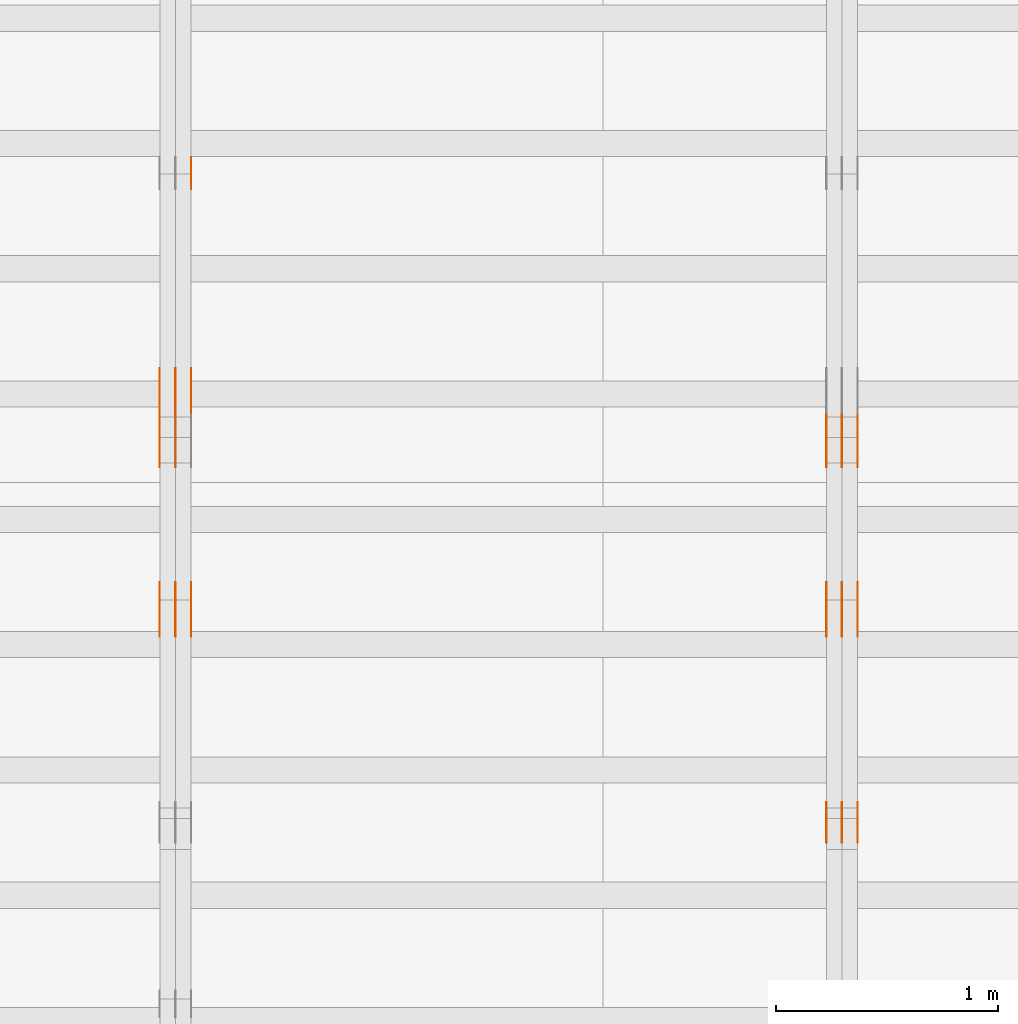
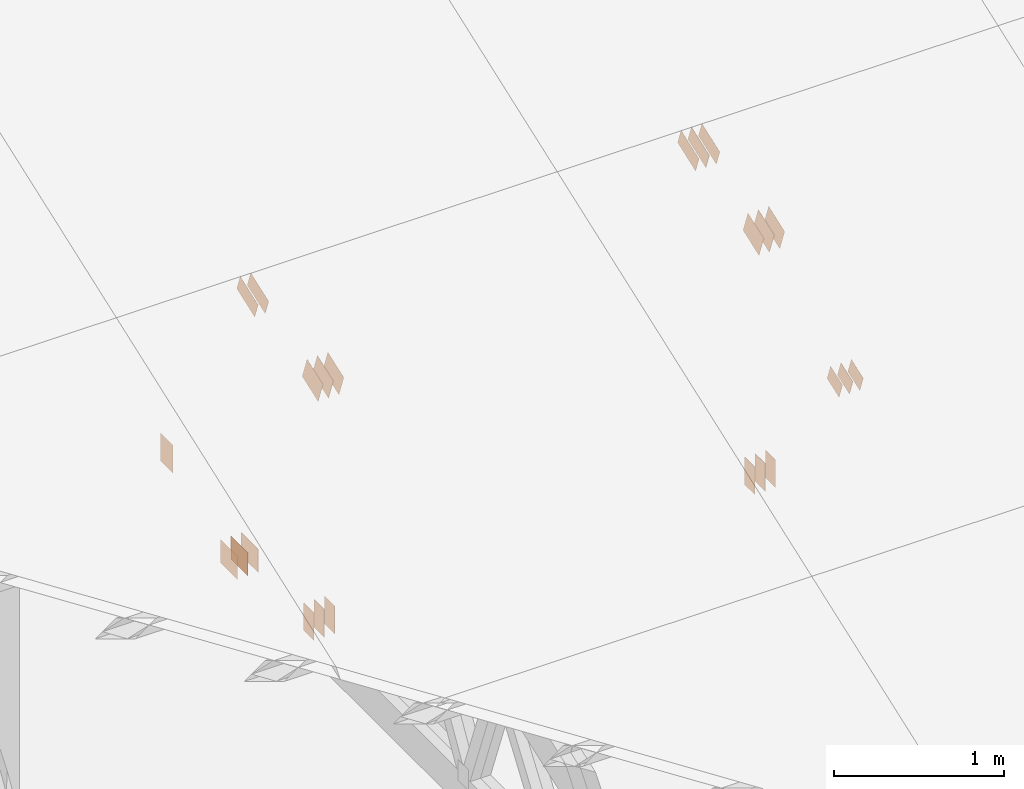
# One storey, part 87 of 189: 31 proxies.
"""IFC2X3 building model written with IfcOpenShell, lengths in millimetres."""

from ifc_helpers import new_model, entity, si_unit, converted_unit, derived_unit, direction, frame, frame_2d, origin, origin_2d_with_axis, place, context, subcontext, project, spatial, polyline, rectangle, outline, extrude, source, transform, mapped, material, type_object, type_shapes, element, save


model = new_model("IFC2X3")

# Units and contexts
model_context = context("Model", 3, precision=0.01, world=origin(), true_north=direction((6.12303176911189e-17, 1.0)))
body_context = subcontext(model_context, "Body", "Model", "MODEL_VIEW")
ifc_project = project(units=[si_unit("LENGTHUNIT", "METRE", prefix="MILLI"), si_unit("AREAUNIT", "SQUARE_METRE"), si_unit("VOLUMEUNIT", "CUBIC_METRE"), converted_unit("PLANEANGLEUNIT", "DEGREE", entity("IfcRatioMeasure", 0.0174532925199433), si_unit("PLANEANGLEUNIT", "RADIAN"), dimensions=[0, 0, 0, 0, 0, 0, 0]), si_unit("MASSUNIT", "GRAM", prefix="KILO"), derived_unit("MASSDENSITYUNIT", [(si_unit("MASSUNIT", "GRAM", prefix="KILO"), 1), (si_unit("LENGTHUNIT", "METRE"), -3)]), si_unit("TIMEUNIT", "SECOND"), si_unit("FREQUENCYUNIT", "HERTZ"), si_unit("THERMODYNAMICTEMPERATUREUNIT", "DEGREE_CELSIUS"), derived_unit("THERMALTRANSMITTANCEUNIT", [(si_unit("MASSUNIT", "GRAM", prefix="KILO"), 1), (si_unit("THERMODYNAMICTEMPERATUREUNIT", "KELVIN"), -1), (si_unit("TIMEUNIT", "SECOND"), -3)]), derived_unit("VOLUMETRICFLOWRATEUNIT", [(si_unit("LENGTHUNIT", "METRE"), 3), (si_unit("TIMEUNIT", "SECOND"), -1)]), si_unit("ELECTRICCURRENTUNIT", "AMPERE"), si_unit("ELECTRICVOLTAGEUNIT", "VOLT"), si_unit("POWERUNIT", "WATT"), si_unit("FORCEUNIT", "NEWTON"), si_unit("ILLUMINANCEUNIT", "LUX"), si_unit("LUMINOUSFLUXUNIT", "LUMEN"), si_unit("LUMINOUSINTENSITYUNIT", "CANDELA"), derived_unit("USERDEFINED", [(si_unit("MASSUNIT", "GRAM", prefix="KILO"), -1), (si_unit("LENGTHUNIT", "METRE"), -2), (si_unit("TIMEUNIT", "SECOND"), 3), (si_unit("LUMINOUSFLUXUNIT", "LUMEN"), 1)]), derived_unit("LINEARVELOCITYUNIT", [(si_unit("LENGTHUNIT", "METRE"), 1), (si_unit("TIMEUNIT", "SECOND"), -1)]), si_unit("PRESSUREUNIT", "PASCAL"), derived_unit("USERDEFINED", [(si_unit("LENGTHUNIT", "METRE"), -2), (si_unit("MASSUNIT", "GRAM", prefix="KILO"), 1), (si_unit("TIMEUNIT", "SECOND"), -2)])], contexts=[model_context])

# Site, building, storey
site_placement = place(None, origin())
site = spatial("IfcSite", under=ifc_project, at=site_placement, CompositionType="ELEMENT")
building_placement = place(site_placement, origin())
building = spatial("IfcBuilding", under=site, at=building_placement, CompositionType="ELEMENT")
storey_placement = place(building_placement, origin())
storey = spatial("IfcBuildingStorey", under=building, at=storey_placement, Name="Default", CompositionType="ELEMENT", Elevation=0.0)

# Proxies
ifc_material_1 = material(Name="IfcSurfaceStyle #106706")
building_element_proxy_type_1 = type_object("IfcBuildingElementProxyType", PredefinedType="NOTDEFINED", material=ifc_material_1)
shared_shape_1 = source(origin(), body_context, "Body", "SweptSolid", [
    extrude(outline(polyline([(-112.500654374667, -59.9999021691247), (112.500117969231, -59.9999021691247), (112.500612624162, 59.9999021691247), (-112.500076218726, 59.9999021691247), (-112.500654374667, -59.9999021691247)])), frame((112.500612624162, 60.0003514046321, 0.0), z_axis=(0.0, 0.0, 1.0), x_axis=(-1.0, 0.0, 0.0)), (0.0, 0.0, 1.0), 1.3),
])
type_shapes(building_element_proxy_type_1, [shared_shape_1])
proxy_1_placement = place(building_placement, frame((18301.3, 5418.0703125, 2162.37353515625), z_axis=(-1.0, 0.0, 0.0), x_axis=(0.0, 0.939692620785908, 0.342020143325669)))
element("IfcBuildingElementProxy", 1, at=proxy_1_placement, inside=storey, type_object=building_element_proxy_type_1, material=ifc_material_1, context=body_context, shape_type="MappedRepresentation", body=[
    mapped(shared_shape_1, transform((0.0, 0.0, 0.0), scale=1.0)),
])
ifc_material_2 = material(Name="IfcSurfaceStyle #106649")
building_element_proxy_type_2 = type_object("IfcBuildingElementProxyType", PredefinedType="NOTDEFINED", material=ifc_material_2)
shared_shape_2 = source(origin(), body_context, "Body", "SweptSolid", [
    extrude(outline(polyline([(-112.500654374667, -59.9999021691247), (112.500117969231, -59.9999021691247), (112.500612624162, 59.9999021691247), (-112.500076218726, 59.9999021691247), (-112.500654374667, -59.9999021691247)])), frame((112.500612624162, 60.0003514046321, 0.0), z_axis=(0.0, 0.0, 1.0), x_axis=(-1.0, 0.0, 0.0)), (0.0, 0.0, 1.0), 1.29999999999998),
])
type_shapes(building_element_proxy_type_2, [shared_shape_2])
proxy_2_placement = place(building_placement, frame((18230.0, 5418.0703125, 2162.37353515625), z_axis=(-1.0, 0.0, 0.0), x_axis=(0.0, 0.939692620785908, 0.342020143325669)))
element("IfcBuildingElementProxy", 2, at=proxy_2_placement, inside=storey, type_object=building_element_proxy_type_2, material=ifc_material_2, context=body_context, shape_type="MappedRepresentation", body=[
    mapped(shared_shape_2, transform((0.0, 0.0, 0.0), scale=1.0)),
])
ifc_material_3 = material(Name="IfcSurfaceStyle #106592")
building_element_proxy_type_3 = type_object("IfcBuildingElementProxyType", PredefinedType="NOTDEFINED", material=ifc_material_3)
shared_shape_3 = source(origin(), body_context, "Body", "SweptSolid", [
    extrude(outline(polyline([(-112.500654374667, -59.9999021691247), (112.500117969231, -59.9999021691247), (112.500612624162, 59.9999021691247), (-112.500076218726, 59.9999021691247), (-112.500654374667, -59.9999021691247)])), frame((112.500612624162, 60.0003514046321, 0.0), z_axis=(0.0, 0.0, 1.0), x_axis=(-1.0, 0.0, 0.0)), (0.0, 0.0, 1.0), 1.29999999999998),
])
type_shapes(building_element_proxy_type_3, [shared_shape_3])
proxy_3_placement = place(building_placement, frame((18231.3, 5418.0703125, 2162.37353515625), z_axis=(-1.0, 0.0, 0.0), x_axis=(0.0, 0.939692620785908, 0.342020143325669)))
element("IfcBuildingElementProxy", 3, at=proxy_3_placement, inside=storey, type_object=building_element_proxy_type_3, material=ifc_material_3, context=body_context, shape_type="MappedRepresentation", body=[
    mapped(shared_shape_3, transform((0.0, 0.0, 0.0), scale=1.0)),
])
ifc_material_4 = material(Name="IfcSurfaceStyle #106535")
building_element_proxy_type_4 = type_object("IfcBuildingElementProxyType", PredefinedType="NOTDEFINED", material=ifc_material_4)
shared_shape_4 = source(origin(), body_context, "Body", "SweptSolid", [
    extrude(outline(polyline([(-112.500654374667, -59.9999021691247), (112.500117969231, -59.9999021691247), (112.500612624162, 59.9999021691247), (-112.500076218726, 59.9999021691247), (-112.500654374667, -59.9999021691247)])), frame((112.500612624162, 60.0003514046321, 0.0), z_axis=(0.0, 0.0, 1.0), x_axis=(-1.0, 0.0, 0.0)), (0.0, 0.0, 1.0), 1.29999999999999),
])
type_shapes(building_element_proxy_type_4, [shared_shape_4])
proxy_4_placement = place(building_placement, frame((18160.0, 5418.0703125, 2162.37353515625), z_axis=(-1.0, 0.0, 0.0), x_axis=(0.0, 0.939692620785908, 0.342020143325669)))
element("IfcBuildingElementProxy", 4, at=proxy_4_placement, inside=storey, type_object=building_element_proxy_type_4, material=ifc_material_4, context=body_context, shape_type="MappedRepresentation", body=[
    mapped(shared_shape_4, transform((0.0, 0.0, 0.0), scale=1.0)),
])
ifc_material_5 = material(Name="IfcSurfaceStyle #106022")
building_element_proxy_type_5 = type_object("IfcBuildingElementProxyType", PredefinedType="NOTDEFINED", material=ifc_material_5)
shared_shape_5 = source(origin(), body_context, "Body", "SweptSolid", [
    extrude(rectangle(XDim=200.0, YDim=120.0, at=origin_2d_with_axis()), frame((100.0, 60.0, 0.0), z_axis=(0.0, 0.0, 1.0), x_axis=(-1.0, 0.0, 0.0)), (0.0, 0.0, 1.0), 1.3),
])
type_shapes(building_element_proxy_type_5, [shared_shape_5])
proxy_5_placement = place(building_placement, frame((18301.3, 4760.65625, 145.0), z_axis=(-1.0, 0.0, 0.0), x_axis=(0.0, 0.0, 1.0)))
element("IfcBuildingElementProxy", 5, at=proxy_5_placement, inside=storey, type_object=building_element_proxy_type_5, material=ifc_material_5, context=body_context, shape_type="MappedRepresentation", body=[
    mapped(shared_shape_5, transform((0.0, 0.0, 0.0), scale=1.0)),
])
ifc_material_6 = material(Name="IfcSurfaceStyle #105965")
building_element_proxy_type_6 = type_object("IfcBuildingElementProxyType", PredefinedType="NOTDEFINED", material=ifc_material_6)
shared_shape_6 = source(origin(), body_context, "Body", "SweptSolid", [
    extrude(rectangle(XDim=200.0, YDim=120.0, at=origin_2d_with_axis()), frame((100.0, 60.0, 0.0), z_axis=(0.0, 0.0, 1.0), x_axis=(-1.0, 0.0, 0.0)), (0.0, 0.0, 1.0), 1.29999999999998),
])
type_shapes(building_element_proxy_type_6, [shared_shape_6])
proxy_6_placement = place(building_placement, frame((18230.0, 4760.65625, 145.0), z_axis=(-1.0, 0.0, 0.0), x_axis=(0.0, 0.0, 1.0)))
element("IfcBuildingElementProxy", 6, at=proxy_6_placement, inside=storey, type_object=building_element_proxy_type_6, material=ifc_material_6, context=body_context, shape_type="MappedRepresentation", body=[
    mapped(shared_shape_6, transform((0.0, 0.0, 0.0), scale=1.0)),
])
ifc_material_7 = material(Name="IfcSurfaceStyle #105908")
building_element_proxy_type_7 = type_object("IfcBuildingElementProxyType", PredefinedType="NOTDEFINED", material=ifc_material_7)
shared_shape_7 = source(origin(), body_context, "Body", "SweptSolid", [
    extrude(rectangle(XDim=200.0, YDim=120.0, at=origin_2d_with_axis()), frame((100.0, 60.0, 0.0), z_axis=(0.0, 0.0, 1.0), x_axis=(-1.0, 0.0, 0.0)), (0.0, 0.0, 1.0), 1.29999999999998),
])
type_shapes(building_element_proxy_type_7, [shared_shape_7])
proxy_7_placement = place(building_placement, frame((18231.3, 4760.65625, 145.0), z_axis=(-1.0, 0.0, 0.0), x_axis=(0.0, 0.0, 1.0)))
element("IfcBuildingElementProxy", 7, at=proxy_7_placement, inside=storey, type_object=building_element_proxy_type_7, material=ifc_material_7, context=body_context, shape_type="MappedRepresentation", body=[
    mapped(shared_shape_7, transform((0.0, 0.0, 0.0), scale=1.0)),
])
ifc_material_8 = material(Name="IfcSurfaceStyle #105851")
building_element_proxy_type_8 = type_object("IfcBuildingElementProxyType", PredefinedType="NOTDEFINED", material=ifc_material_8)
shared_shape_8 = source(origin(), body_context, "Body", "SweptSolid", [
    extrude(rectangle(XDim=200.0, YDim=120.0, at=origin_2d_with_axis()), frame((100.0, 60.0, 0.0), z_axis=(0.0, 0.0, 1.0), x_axis=(-1.0, 0.0, 0.0)), (0.0, 0.0, 1.0), 1.29999999999999),
])
type_shapes(building_element_proxy_type_8, [shared_shape_8])
proxy_8_placement = place(building_placement, frame((18160.0, 4760.65625, 145.0), z_axis=(-1.0, 0.0, 0.0), x_axis=(0.0, 0.0, 1.0)))
element("IfcBuildingElementProxy", 8, at=proxy_8_placement, inside=storey, type_object=building_element_proxy_type_8, material=ifc_material_8, context=body_context, shape_type="MappedRepresentation", body=[
    mapped(shared_shape_8, transform((0.0, 0.0, 0.0), scale=1.0)),
])
ifc_material_9 = material(Name="IfcSurfaceStyle #105794")
building_element_proxy_type_9 = type_object("IfcBuildingElementProxyType", PredefinedType="NOTDEFINED", material=ifc_material_9)
shared_shape_9 = source(origin(), body_context, "Body", "SweptSolid", [
    extrude(outline(polyline([(-74.9994515581384, -59.9999039432178), (74.9998536965286, -59.9999039432178), (75.0003483514593, 59.9999039432178), (-75.0007504898495, 59.9999039432178), (-74.9994515581384, -59.9999039432178)])), frame((75.0003483514593, 60.0003496305408, 0.0), z_axis=(0.0, 0.0, 1.0), x_axis=(-1.0, 0.0, 0.0)), (0.0, 0.0, 1.0), 1.3),
])
type_shapes(building_element_proxy_type_9, [shared_shape_9])
proxy_9_placement = place(building_placement, frame((18301.3, 3726.8984375, 1559.607421875), z_axis=(-1.0, 0.0, 0.0), x_axis=(0.0, 0.939692620785908, 0.342020143325669)))
element("IfcBuildingElementProxy", 9, at=proxy_9_placement, inside=storey, type_object=building_element_proxy_type_9, material=ifc_material_9, context=body_context, shape_type="MappedRepresentation", body=[
    mapped(shared_shape_9, transform((0.0, 0.0, 0.0), scale=1.0)),
])
ifc_material_10 = material(Name="IfcSurfaceStyle #105737")
building_element_proxy_type_10 = type_object("IfcBuildingElementProxyType", PredefinedType="NOTDEFINED", material=ifc_material_10)
shared_shape_10 = source(origin(), body_context, "Body", "SweptSolid", [
    extrude(outline(polyline([(-74.9994515581384, -59.9999039432178), (74.9998536965286, -59.9999039432178), (75.0003483514593, 59.9999039432178), (-75.0007504898495, 59.9999039432178), (-74.9994515581384, -59.9999039432178)])), frame((75.0003483514593, 60.0003496305408, 0.0), z_axis=(0.0, 0.0, 1.0), x_axis=(-1.0, 0.0, 0.0)), (0.0, 0.0, 1.0), 1.29999999999999),
])
type_shapes(building_element_proxy_type_10, [shared_shape_10])
proxy_10_placement = place(building_placement, frame((18230.0, 3726.8984375, 1559.607421875), z_axis=(-1.0, 0.0, 0.0), x_axis=(0.0, 0.939692620785908, 0.342020143325669)))
element("IfcBuildingElementProxy", 10, at=proxy_10_placement, inside=storey, type_object=building_element_proxy_type_10, material=ifc_material_10, context=body_context, shape_type="MappedRepresentation", body=[
    mapped(shared_shape_10, transform((0.0, 0.0, 0.0), scale=1.0)),
])
ifc_material_11 = material(Name="IfcSurfaceStyle #105680")
building_element_proxy_type_11 = type_object("IfcBuildingElementProxyType", PredefinedType="NOTDEFINED", material=ifc_material_11)
shared_shape_11 = source(origin(), body_context, "Body", "SweptSolid", [
    extrude(outline(polyline([(-74.9994515581384, -59.9999039432178), (74.9998536965286, -59.9999039432178), (75.0003483514593, 59.9999039432178), (-75.0007504898495, 59.9999039432178), (-74.9994515581384, -59.9999039432178)])), frame((75.0003483514593, 60.0003496305408, 0.0), z_axis=(0.0, 0.0, 1.0), x_axis=(-1.0, 0.0, 0.0)), (0.0, 0.0, 1.0), 1.29999999999999),
])
type_shapes(building_element_proxy_type_11, [shared_shape_11])
proxy_11_placement = place(building_placement, frame((18231.3, 3726.8984375, 1559.607421875), z_axis=(-1.0, 0.0, 0.0), x_axis=(0.0, 0.939692620785908, 0.342020143325669)))
element("IfcBuildingElementProxy", 11, at=proxy_11_placement, inside=storey, type_object=building_element_proxy_type_11, material=ifc_material_11, context=body_context, shape_type="MappedRepresentation", body=[
    mapped(shared_shape_11, transform((0.0, 0.0, 0.0), scale=1.0)),
])
ifc_material_12 = material(Name="IfcSurfaceStyle #105623")
building_element_proxy_type_12 = type_object("IfcBuildingElementProxyType", PredefinedType="NOTDEFINED", material=ifc_material_12)
shared_shape_12 = source(origin(), body_context, "Body", "SweptSolid", [
    extrude(outline(polyline([(-74.9994515581384, -59.9999039432178), (74.9998536965286, -59.9999039432178), (75.0003483514593, 59.9999039432178), (-75.0007504898495, 59.9999039432178), (-74.9994515581384, -59.9999039432178)])), frame((75.0003483514593, 60.0003496305408, 0.0), z_axis=(0.0, 0.0, 1.0), x_axis=(-1.0, 0.0, 0.0)), (0.0, 0.0, 1.0), 1.29999999999999),
])
type_shapes(building_element_proxy_type_12, [shared_shape_12])
proxy_12_placement = place(building_placement, frame((18160.0, 3726.8984375, 1559.607421875), z_axis=(-1.0, 0.0, 0.0), x_axis=(0.0, 0.939692620785908, 0.342020143325669)))
element("IfcBuildingElementProxy", 12, at=proxy_12_placement, inside=storey, type_object=building_element_proxy_type_12, material=ifc_material_12, context=body_context, shape_type="MappedRepresentation", body=[
    mapped(shared_shape_12, transform((0.0, 0.0, 0.0), scale=1.0)),
])
ifc_material_13 = material(Name="IfcSurfaceStyle #101126")
building_element_proxy_type_13 = type_object("IfcBuildingElementProxyType", PredefinedType="NOTDEFINED", material=ifc_material_13)
shared_shape_13 = source(origin(), body_context, "Body", "SweptSolid", [
    extrude(outline(polyline([(-99.9993269270171, -84.0000832532405), (99.9997189122032, -84.0000832532405), (99.9992851765118, 84.0000832532405), (-99.999677161698, 84.0000832532405), (-99.9993269270171, -84.0000832532405)])), frame((99.9999283659736, 84.0000832532405, 0.0), z_axis=(0.0, 0.0, 1.0), x_axis=(-1.0, 0.0, 0.0)), (0.0, 0.0, 1.0), 1.3),
])
type_shapes(building_element_proxy_type_13, [shared_shape_13])
proxy_13_placement = place(building_placement, frame((18301.3, 4654.06379965055, 2052.96988554922), z_axis=(-1.0, 0.0, 0.0), x_axis=(0.0, 0.939692620785908, 0.342020143325669)))
element("IfcBuildingElementProxy", 13, at=proxy_13_placement, inside=storey, type_object=building_element_proxy_type_13, material=ifc_material_13, context=body_context, shape_type="MappedRepresentation", body=[
    mapped(shared_shape_13, transform((0.0, 0.0, 0.0), scale=1.0)),
])
ifc_material_14 = material(Name="IfcSurfaceStyle #101069")
building_element_proxy_type_14 = type_object("IfcBuildingElementProxyType", PredefinedType="NOTDEFINED", material=ifc_material_14)
shared_shape_14 = source(origin(), body_context, "Body", "SweptSolid", [
    extrude(outline(polyline([(-99.9993269270171, -84.0000832532405), (99.9997189122032, -84.0000832532405), (99.9992851765118, 84.0000832532405), (-99.999677161698, 84.0000832532405), (-99.9993269270171, -84.0000832532405)])), frame((99.9999283659736, 84.0000832532405, 0.0), z_axis=(0.0, 0.0, 1.0), x_axis=(-1.0, 0.0, 0.0)), (0.0, 0.0, 1.0), 1.29999999999998),
])
type_shapes(building_element_proxy_type_14, [shared_shape_14])
proxy_14_placement = place(building_placement, frame((18230.0, 4654.06379965055, 2052.96988554922), z_axis=(-1.0, 0.0, 0.0), x_axis=(0.0, 0.939692620785908, 0.342020143325669)))
element("IfcBuildingElementProxy", 14, at=proxy_14_placement, inside=storey, type_object=building_element_proxy_type_14, material=ifc_material_14, context=body_context, shape_type="MappedRepresentation", body=[
    mapped(shared_shape_14, transform((0.0, 0.0, 0.0), scale=1.0)),
])
ifc_material_15 = material(Name="IfcSurfaceStyle #101012")
building_element_proxy_type_15 = type_object("IfcBuildingElementProxyType", PredefinedType="NOTDEFINED", material=ifc_material_15)
shared_shape_15 = source(origin(), body_context, "Body", "SweptSolid", [
    extrude(outline(polyline([(-99.9993269270171, -84.0000832532405), (99.9997189122032, -84.0000832532405), (99.9992851765118, 84.0000832532405), (-99.999677161698, 84.0000832532405), (-99.9993269270171, -84.0000832532405)])), frame((99.9999283659736, 84.0000832532405, 0.0), z_axis=(0.0, 0.0, 1.0), x_axis=(-1.0, 0.0, 0.0)), (0.0, 0.0, 1.0), 1.29999999999998),
])
type_shapes(building_element_proxy_type_15, [shared_shape_15])
proxy_15_placement = place(building_placement, frame((18231.3, 4654.06379965055, 2052.96988554922), z_axis=(-1.0, 0.0, 0.0), x_axis=(0.0, 0.939692620785908, 0.342020143325669)))
element("IfcBuildingElementProxy", 15, at=proxy_15_placement, inside=storey, type_object=building_element_proxy_type_15, material=ifc_material_15, context=body_context, shape_type="MappedRepresentation", body=[
    mapped(shared_shape_15, transform((0.0, 0.0, 0.0), scale=1.0)),
])
ifc_material_16 = material(Name="IfcSurfaceStyle #100955")
building_element_proxy_type_16 = type_object("IfcBuildingElementProxyType", PredefinedType="NOTDEFINED", material=ifc_material_16)
shared_shape_16 = source(origin(), body_context, "Body", "SweptSolid", [
    extrude(outline(polyline([(-99.9993269270171, -84.0000832532405), (99.9997189122032, -84.0000832532405), (99.9992851765118, 84.0000832532405), (-99.999677161698, 84.0000832532405), (-99.9993269270171, -84.0000832532405)])), frame((99.9999283659736, 84.0000832532405, 0.0), z_axis=(0.0, 0.0, 1.0), x_axis=(-1.0, 0.0, 0.0)), (0.0, 0.0, 1.0), 1.29999999999999),
])
type_shapes(building_element_proxy_type_16, [shared_shape_16])
proxy_16_placement = place(building_placement, frame((18160.0, 4654.06379965055, 2052.96988554922), z_axis=(-1.0, 0.0, 0.0), x_axis=(0.0, 0.939692620785908, 0.342020143325669)))
element("IfcBuildingElementProxy", 16, at=proxy_16_placement, inside=storey, type_object=building_element_proxy_type_16, material=ifc_material_16, context=body_context, shape_type="MappedRepresentation", body=[
    mapped(shared_shape_16, transform((0.0, 0.0, 0.0), scale=1.0)),
])
ifc_material_17 = material(Name="IfcSurfaceStyle #94792")
building_element_proxy_type_17 = type_object("IfcBuildingElementProxyType", PredefinedType="NOTDEFINED", material=ifc_material_17)
shared_shape_17 = source(origin(), body_context, "Body", "SweptSolid", [
    extrude(rectangle(XDim=200.0, YDim=144.0, at=frame_2d((1.4210854715202e-14, 0.0), x_axis=(1.0, 0.0))), frame((100.0, 72.0, 0.0), z_axis=(0.0, 0.0, 1.0), x_axis=(-1.0, 0.0, 0.0)), (0.0, 0.0, 1.0), 1.3),
])
type_shapes(building_element_proxy_type_17, [shared_shape_17])
proxy_17_placement = place(building_placement, frame((15301.3, 6668.833984375, 145.0), z_axis=(-1.0, 0.0, 0.0), x_axis=(0.0, 0.0, 1.0)))
element("IfcBuildingElementProxy", 17, at=proxy_17_placement, inside=storey, type_object=building_element_proxy_type_17, material=ifc_material_17, context=body_context, shape_type="MappedRepresentation", body=[
    mapped(shared_shape_17, transform((0.0, 0.0, 0.0), scale=1.0)),
])
ifc_material_18 = material(Name="IfcSurfaceStyle #94564")
building_element_proxy_type_18 = type_object("IfcBuildingElementProxyType", PredefinedType="NOTDEFINED", material=ifc_material_18)
shared_shape_18 = source(origin(), body_context, "Body", "SweptSolid", [
    extrude(rectangle(XDim=200.0, YDim=168.0, at=origin_2d_with_axis()), frame((100.0, 84.0, 0.0), z_axis=(0.0, 0.0, 1.0), x_axis=(-1.0, 0.0, 0.0)), (0.0, 0.0, 1.0), 1.3),
])
type_shapes(building_element_proxy_type_18, [shared_shape_18])
proxy_18_placement = place(building_placement, frame((15301.3, 5662.466796875, 206.5), z_axis=(-1.0, 0.0, 0.0), x_axis=(0.0, 1.0, 0.0)))
element("IfcBuildingElementProxy", 18, at=proxy_18_placement, inside=storey, type_object=building_element_proxy_type_18, material=ifc_material_18, context=body_context, shape_type="MappedRepresentation", body=[
    mapped(shared_shape_18, transform((0.0, 0.0, 0.0), scale=1.0)),
])
ifc_material_19 = material(Name="IfcSurfaceStyle #94507")
building_element_proxy_type_19 = type_object("IfcBuildingElementProxyType", PredefinedType="NOTDEFINED", material=ifc_material_19)
shared_shape_19 = source(origin(), body_context, "Body", "SweptSolid", [
    extrude(rectangle(XDim=200.0, YDim=168.0, at=origin_2d_with_axis()), frame((100.0, 84.0, 0.0), z_axis=(0.0, 0.0, 1.0), x_axis=(-1.0, 0.0, 0.0)), (0.0, 0.0, 1.0), 1.29999999999998),
])
type_shapes(building_element_proxy_type_19, [shared_shape_19])
proxy_19_placement = place(building_placement, frame((15230.0, 5662.466796875, 206.5), z_axis=(-1.0, 0.0, 0.0), x_axis=(0.0, 1.0, 0.0)))
element("IfcBuildingElementProxy", 19, at=proxy_19_placement, inside=storey, type_object=building_element_proxy_type_19, material=ifc_material_19, context=body_context, shape_type="MappedRepresentation", body=[
    mapped(shared_shape_19, transform((0.0, 0.0, 0.0), scale=1.0)),
])
ifc_material_20 = material(Name="IfcSurfaceStyle #94450")
building_element_proxy_type_20 = type_object("IfcBuildingElementProxyType", PredefinedType="NOTDEFINED", material=ifc_material_20)
shared_shape_20 = source(origin(), body_context, "Body", "SweptSolid", [
    extrude(rectangle(XDim=200.0, YDim=168.0, at=origin_2d_with_axis()), frame((100.0, 84.0, 0.0), z_axis=(0.0, 0.0, 1.0), x_axis=(-1.0, 0.0, 0.0)), (0.0, 0.0, 1.0), 1.29999999999998),
])
type_shapes(building_element_proxy_type_20, [shared_shape_20])
proxy_20_placement = place(building_placement, frame((15231.3, 5662.466796875, 206.5), z_axis=(-1.0, 0.0, 0.0), x_axis=(0.0, 1.0, 0.0)))
element("IfcBuildingElementProxy", 20, at=proxy_20_placement, inside=storey, type_object=building_element_proxy_type_20, material=ifc_material_20, context=body_context, shape_type="MappedRepresentation", body=[
    mapped(shared_shape_20, transform((0.0, 0.0, 0.0), scale=1.0)),
])
ifc_material_21 = material(Name="IfcSurfaceStyle #94393")
building_element_proxy_type_21 = type_object("IfcBuildingElementProxyType", PredefinedType="NOTDEFINED", material=ifc_material_21)
shared_shape_21 = source(origin(), body_context, "Body", "SweptSolid", [
    extrude(rectangle(XDim=200.0, YDim=168.0, at=origin_2d_with_axis()), frame((100.0, 84.0, 0.0), z_axis=(0.0, 0.0, 1.0), x_axis=(-1.0, 0.0, 0.0)), (0.0, 0.0, 1.0), 1.29999999999999),
])
type_shapes(building_element_proxy_type_21, [shared_shape_21])
proxy_21_placement = place(building_placement, frame((15160.0, 5662.466796875, 206.5), z_axis=(-1.0, 0.0, 0.0), x_axis=(0.0, 1.0, 0.0)))
element("IfcBuildingElementProxy", 21, at=proxy_21_placement, inside=storey, type_object=building_element_proxy_type_21, material=ifc_material_21, context=body_context, shape_type="MappedRepresentation", body=[
    mapped(shared_shape_21, transform((0.0, 0.0, 0.0), scale=1.0)),
])
ifc_material_22 = material(Name="IfcSurfaceStyle #90802")
building_element_proxy_type_22 = type_object("IfcBuildingElementProxyType", PredefinedType="NOTDEFINED", material=ifc_material_22)
shared_shape_22 = source(origin(), body_context, "Body", "SweptSolid", [
    extrude(outline(polyline([(-112.500654374667, -59.9999021691247), (112.500117969231, -59.9999021691247), (112.500612624162, 59.9999021691247), (-112.500076218726, 59.9999021691247), (-112.500654374667, -59.9999021691247)])), frame((112.500612624162, 60.0003514046321, 0.0), z_axis=(0.0, 0.0, 1.0), x_axis=(-1.0, 0.0, 0.0)), (0.0, 0.0, 1.0), 1.29999999999998),
])
type_shapes(building_element_proxy_type_22, [shared_shape_22])
proxy_22_placement = place(building_placement, frame((15231.3, 5418.0703125, 2162.37353515625), z_axis=(-1.0, 0.0, 0.0), x_axis=(0.0, 0.939692620785908, 0.342020143325669)))
element("IfcBuildingElementProxy", 22, at=proxy_22_placement, inside=storey, type_object=building_element_proxy_type_22, material=ifc_material_22, context=body_context, shape_type="MappedRepresentation", body=[
    mapped(shared_shape_22, transform((0.0, 0.0, 0.0), scale=1.0)),
])
ifc_material_23 = material(Name="IfcSurfaceStyle #90745")
building_element_proxy_type_23 = type_object("IfcBuildingElementProxyType", PredefinedType="NOTDEFINED", material=ifc_material_23)
shared_shape_23 = source(origin(), body_context, "Body", "SweptSolid", [
    extrude(outline(polyline([(-112.500654374667, -59.9999021691247), (112.500117969231, -59.9999021691247), (112.500612624162, 59.9999021691247), (-112.500076218726, 59.9999021691247), (-112.500654374667, -59.9999021691247)])), frame((112.500612624162, 60.0003514046321, 0.0), z_axis=(0.0, 0.0, 1.0), x_axis=(-1.0, 0.0, 0.0)), (0.0, 0.0, 1.0), 1.29999999999999),
])
type_shapes(building_element_proxy_type_23, [shared_shape_23])
proxy_23_placement = place(building_placement, frame((15160.0, 5418.0703125, 2162.37353515625), z_axis=(-1.0, 0.0, 0.0), x_axis=(0.0, 0.939692620785908, 0.342020143325669)))
element("IfcBuildingElementProxy", 23, at=proxy_23_placement, inside=storey, type_object=building_element_proxy_type_23, material=ifc_material_23, context=body_context, shape_type="MappedRepresentation", body=[
    mapped(shared_shape_23, transform((0.0, 0.0, 0.0), scale=1.0)),
])
ifc_material_24 = material(Name="IfcSurfaceStyle #90232")
building_element_proxy_type_24 = type_object("IfcBuildingElementProxyType", PredefinedType="NOTDEFINED", material=ifc_material_24)
shared_shape_24 = source(origin(), body_context, "Body", "SweptSolid", [
    extrude(rectangle(XDim=200.0, YDim=120.0, at=origin_2d_with_axis()), frame((100.0, 60.0, 0.0), z_axis=(0.0, 0.0, 1.0), x_axis=(-1.0, 0.0, 0.0)), (0.0, 0.0, 1.0), 1.3),
])
type_shapes(building_element_proxy_type_24, [shared_shape_24])
proxy_24_placement = place(building_placement, frame((15301.3, 4760.65625, 145.0), z_axis=(-1.0, 0.0, 0.0), x_axis=(0.0, 0.0, 1.0)))
element("IfcBuildingElementProxy", 24, at=proxy_24_placement, inside=storey, type_object=building_element_proxy_type_24, material=ifc_material_24, context=body_context, shape_type="MappedRepresentation", body=[
    mapped(shared_shape_24, transform((0.0, 0.0, 0.0), scale=1.0)),
])
ifc_material_25 = material(Name="IfcSurfaceStyle #90175")
building_element_proxy_type_25 = type_object("IfcBuildingElementProxyType", PredefinedType="NOTDEFINED", material=ifc_material_25)
shared_shape_25 = source(origin(), body_context, "Body", "SweptSolid", [
    extrude(rectangle(XDim=200.0, YDim=120.0, at=origin_2d_with_axis()), frame((100.0, 60.0, 0.0), z_axis=(0.0, 0.0, 1.0), x_axis=(-1.0, 0.0, 0.0)), (0.0, 0.0, 1.0), 1.29999999999998),
])
type_shapes(building_element_proxy_type_25, [shared_shape_25])
proxy_25_placement = place(building_placement, frame((15230.0, 4760.65625, 145.0), z_axis=(-1.0, 0.0, 0.0), x_axis=(0.0, 0.0, 1.0)))
element("IfcBuildingElementProxy", 25, at=proxy_25_placement, inside=storey, type_object=building_element_proxy_type_25, material=ifc_material_25, context=body_context, shape_type="MappedRepresentation", body=[
    mapped(shared_shape_25, transform((0.0, 0.0, 0.0), scale=1.0)),
])
ifc_material_26 = material(Name="IfcSurfaceStyle #90118")
building_element_proxy_type_26 = type_object("IfcBuildingElementProxyType", PredefinedType="NOTDEFINED", material=ifc_material_26)
shared_shape_26 = source(origin(), body_context, "Body", "SweptSolid", [
    extrude(rectangle(XDim=200.0, YDim=120.0, at=origin_2d_with_axis()), frame((100.0, 60.0, 0.0), z_axis=(0.0, 0.0, 1.0), x_axis=(-1.0, 0.0, 0.0)), (0.0, 0.0, 1.0), 1.29999999999998),
])
type_shapes(building_element_proxy_type_26, [shared_shape_26])
proxy_26_placement = place(building_placement, frame((15231.3, 4760.65625, 145.0), z_axis=(-1.0, 0.0, 0.0), x_axis=(0.0, 0.0, 1.0)))
element("IfcBuildingElementProxy", 26, at=proxy_26_placement, inside=storey, type_object=building_element_proxy_type_26, material=ifc_material_26, context=body_context, shape_type="MappedRepresentation", body=[
    mapped(shared_shape_26, transform((0.0, 0.0, 0.0), scale=1.0)),
])
ifc_material_27 = material(Name="IfcSurfaceStyle #90061")
building_element_proxy_type_27 = type_object("IfcBuildingElementProxyType", PredefinedType="NOTDEFINED", material=ifc_material_27)
shared_shape_27 = source(origin(), body_context, "Body", "SweptSolid", [
    extrude(rectangle(XDim=200.0, YDim=120.0, at=origin_2d_with_axis()), frame((100.0, 60.0, 0.0), z_axis=(0.0, 0.0, 1.0), x_axis=(-1.0, 0.0, 0.0)), (0.0, 0.0, 1.0), 1.29999999999999),
])
type_shapes(building_element_proxy_type_27, [shared_shape_27])
proxy_27_placement = place(building_placement, frame((15160.0, 4760.65625, 145.0), z_axis=(-1.0, 0.0, 0.0), x_axis=(0.0, 0.0, 1.0)))
element("IfcBuildingElementProxy", 27, at=proxy_27_placement, inside=storey, type_object=building_element_proxy_type_27, material=ifc_material_27, context=body_context, shape_type="MappedRepresentation", body=[
    mapped(shared_shape_27, transform((0.0, 0.0, 0.0), scale=1.0)),
])
ifc_material_28 = material(Name="IfcSurfaceStyle #85336")
building_element_proxy_type_28 = type_object("IfcBuildingElementProxyType", PredefinedType="NOTDEFINED", material=ifc_material_28)
shared_shape_28 = source(origin(), body_context, "Body", "SweptSolid", [
    extrude(outline(polyline([(-99.9993269270171, -84.0000832532405), (99.9997189122032, -84.0000832532405), (99.9992851765118, 84.0000832532405), (-99.999677161698, 84.0000832532405), (-99.9993269270171, -84.0000832532405)])), frame((99.9999283659736, 84.0000832532405, 0.0), z_axis=(0.0, 0.0, 1.0), x_axis=(-1.0, 0.0, 0.0)), (0.0, 0.0, 1.0), 1.3),
])
type_shapes(building_element_proxy_type_28, [shared_shape_28])
proxy_28_placement = place(building_placement, frame((15301.3, 4654.06379965055, 2052.96988554922), z_axis=(-1.0, 0.0, 0.0), x_axis=(0.0, 0.939692620785908, 0.342020143325669)))
element("IfcBuildingElementProxy", 28, at=proxy_28_placement, inside=storey, type_object=building_element_proxy_type_28, material=ifc_material_28, context=body_context, shape_type="MappedRepresentation", body=[
    mapped(shared_shape_28, transform((0.0, 0.0, 0.0), scale=1.0)),
])
ifc_material_29 = material(Name="IfcSurfaceStyle #85279")
building_element_proxy_type_29 = type_object("IfcBuildingElementProxyType", PredefinedType="NOTDEFINED", material=ifc_material_29)
shared_shape_29 = source(origin(), body_context, "Body", "SweptSolid", [
    extrude(outline(polyline([(-99.9993269270171, -84.0000832532405), (99.9997189122032, -84.0000832532405), (99.9992851765118, 84.0000832532405), (-99.999677161698, 84.0000832532405), (-99.9993269270171, -84.0000832532405)])), frame((99.9999283659736, 84.0000832532405, 0.0), z_axis=(0.0, 0.0, 1.0), x_axis=(-1.0, 0.0, 0.0)), (0.0, 0.0, 1.0), 1.29999999999998),
])
type_shapes(building_element_proxy_type_29, [shared_shape_29])
proxy_29_placement = place(building_placement, frame((15230.0, 4654.06379965055, 2052.96988554922), z_axis=(-1.0, 0.0, 0.0), x_axis=(0.0, 0.939692620785908, 0.342020143325669)))
element("IfcBuildingElementProxy", 29, at=proxy_29_placement, inside=storey, type_object=building_element_proxy_type_29, material=ifc_material_29, context=body_context, shape_type="MappedRepresentation", body=[
    mapped(shared_shape_29, transform((0.0, 0.0, 0.0), scale=1.0)),
])
ifc_material_30 = material(Name="IfcSurfaceStyle #85222")
building_element_proxy_type_30 = type_object("IfcBuildingElementProxyType", PredefinedType="NOTDEFINED", material=ifc_material_30)
shared_shape_30 = source(origin(), body_context, "Body", "SweptSolid", [
    extrude(outline(polyline([(-99.9993269270171, -84.0000832532405), (99.9997189122032, -84.0000832532405), (99.9992851765118, 84.0000832532405), (-99.999677161698, 84.0000832532405), (-99.9993269270171, -84.0000832532405)])), frame((99.9999283659736, 84.0000832532405, 0.0), z_axis=(0.0, 0.0, 1.0), x_axis=(-1.0, 0.0, 0.0)), (0.0, 0.0, 1.0), 1.29999999999998),
])
type_shapes(building_element_proxy_type_30, [shared_shape_30])
proxy_30_placement = place(building_placement, frame((15231.3, 4654.06379965055, 2052.96988554922), z_axis=(-1.0, 0.0, 0.0), x_axis=(0.0, 0.939692620785908, 0.342020143325669)))
element("IfcBuildingElementProxy", 30, at=proxy_30_placement, inside=storey, type_object=building_element_proxy_type_30, material=ifc_material_30, context=body_context, shape_type="MappedRepresentation", body=[
    mapped(shared_shape_30, transform((0.0, 0.0, 0.0), scale=1.0)),
])
ifc_material_31 = material(Name="IfcSurfaceStyle #85165")
building_element_proxy_type_31 = type_object("IfcBuildingElementProxyType", PredefinedType="NOTDEFINED", material=ifc_material_31)
shared_shape_31 = source(origin(), body_context, "Body", "SweptSolid", [
    extrude(outline(polyline([(-99.9993269270171, -84.0000832532405), (99.9997189122032, -84.0000832532405), (99.9992851765118, 84.0000832532405), (-99.999677161698, 84.0000832532405), (-99.9993269270171, -84.0000832532405)])), frame((99.9999283659736, 84.0000832532405, 0.0), z_axis=(0.0, 0.0, 1.0), x_axis=(-1.0, 0.0, 0.0)), (0.0, 0.0, 1.0), 1.29999999999999),
])
type_shapes(building_element_proxy_type_31, [shared_shape_31])
proxy_31_placement = place(building_placement, frame((15160.0, 4654.06379965055, 2052.96988554922), z_axis=(-1.0, 0.0, 0.0), x_axis=(0.0, 0.939692620785908, 0.342020143325669)))
element("IfcBuildingElementProxy", 31, at=proxy_31_placement, inside=storey, type_object=building_element_proxy_type_31, material=ifc_material_31, context=body_context, shape_type="MappedRepresentation", body=[
    mapped(shared_shape_31, transform((0.0, 0.0, 0.0), scale=1.0)),
])

save(model, "model.ifc")
